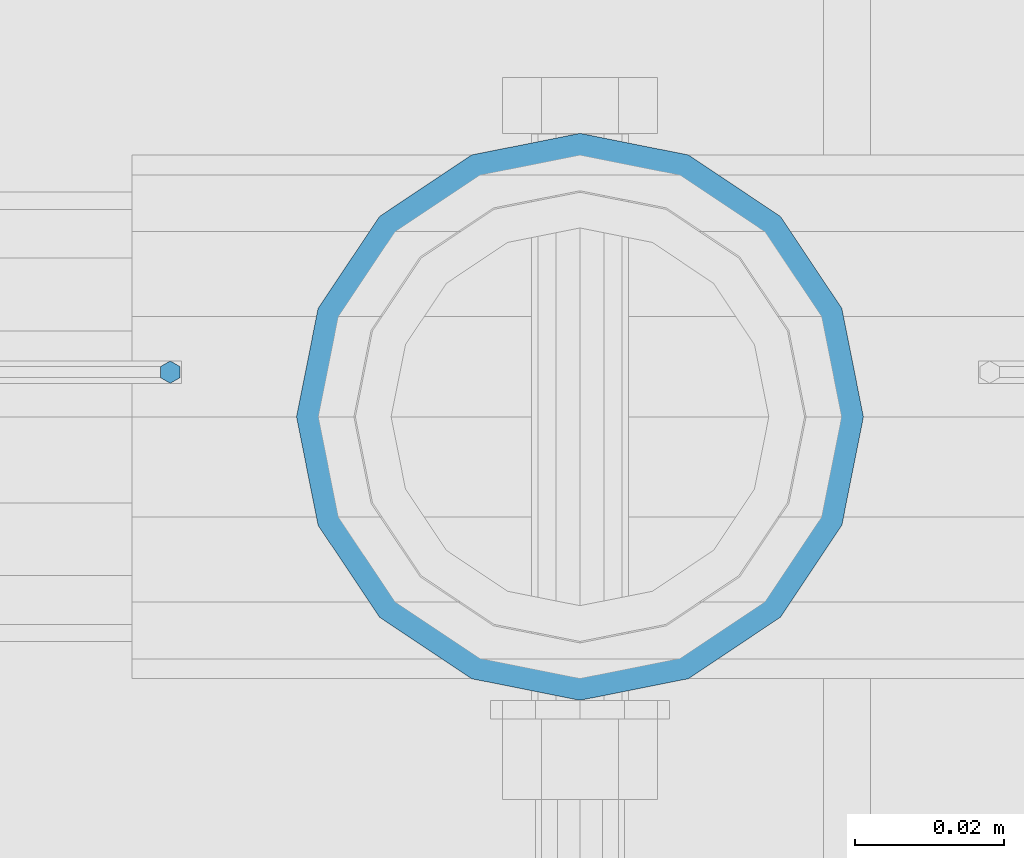
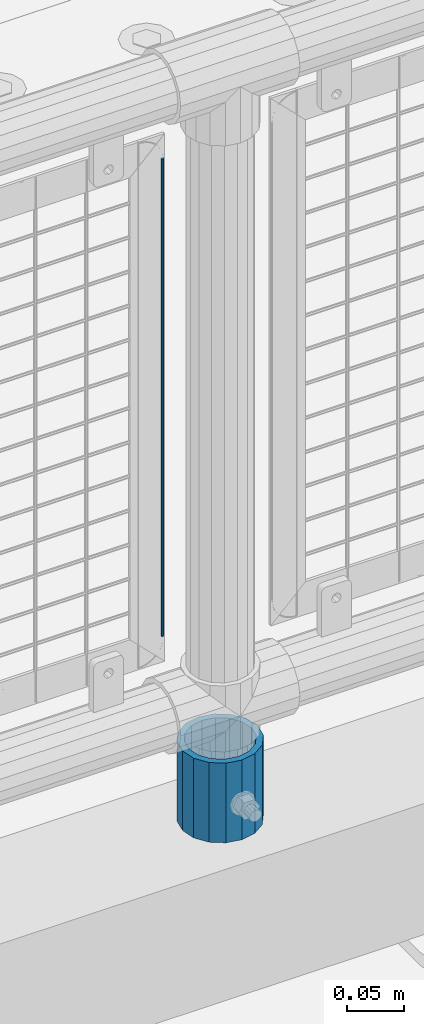
# One storey, part 87 of 240: 2 columns.
"""IFC2X3 building model written with IfcOpenShell, lengths in millimetres."""

from ifc_helpers import new_model, si_unit, frame, origin_with_axes, place, context, subcontext, project, spatial, faceted_brep, material, type_object, element, save


model = new_model("IFC2X3")

# Units and contexts
model_context = context("Model", 3, precision=1e-05, world=origin_with_axes())
body_context = subcontext(model_context, "Body", "Model", "MODEL_VIEW")
ifc_project = project(units=[si_unit("LENGTHUNIT", "METRE", prefix="MILLI"), si_unit("AREAUNIT", "SQUARE_METRE"), si_unit("VOLUMEUNIT", "CUBIC_METRE"), si_unit("MASSUNIT", "GRAM", prefix="KILO"), si_unit("TIMEUNIT", "SECOND"), si_unit("PLANEANGLEUNIT", "RADIAN"), si_unit("SOLIDANGLEUNIT", "STERADIAN"), si_unit("THERMODYNAMICTEMPERATUREUNIT", "DEGREE_CELSIUS"), si_unit("LUMINOUSINTENSITYUNIT", "LUMEN")], contexts=[model_context])

# Site, building, storey
site_placement = place(None, origin_with_axes())
site = spatial("IfcSite", under=ifc_project, at=site_placement, CompositionType="ELEMENT")
building_placement = place(site_placement, origin_with_axes())
building = spatial("IfcBuilding", under=site, at=building_placement, Name="Standard", CompositionType="ELEMENT")
storey_placement = place(building_placement, origin_with_axes())
storey = spatial("IfcBuildingStorey", under=building, at=storey_placement, Name="Undefined", CompositionType="ELEMENT", Elevation=0.0)

# Columns
ifc_material_1 = material(Name="Misc_Undefined")
column_type_1 = type_object("IfcColumnType", Name="D3", PredefinedType="NOTDEFINED")
column_1_placement = place(storey_placement, frame((51306.0, 34670.5, 378.020000000001), z_axis=(-1.0, 0.0, 0.0), x_axis=(0.0, 0.0, 1.0)))
element("IfcColumn", 1, at=column_1_placement, inside=storey, type_object=column_type_1, material=ifc_material_1, ObjectType="D3", context=body_context, shape_type="Brep", body=[
    faceted_brep([(-7.27595761418343e-12, -1.49999999999272, 0.0), (-7.27595761418343e-12, -0.749999999992724, -1.29903810567669), (510.0, -0.75, -1.29903810567339), (510.0, -1.5, 0.0), (0.0, 0.750000000007276, -1.29903810567669), (510.0, 0.75, -1.29903810567339), (0.0, 1.50000000000728, 0.0), (510.0, 1.5, 0.0), (0.0, 0.750000000007276, 1.29903810567669), (510.0, 0.75, 1.29903810567339), (-7.27595761418343e-12, -0.749999999992724, 1.29903810567669), (510.0, -0.75, 1.29903810567339)], [[[0, 1, 2, 3]], [[1, 4, 5, 2]], [[4, 6, 7, 5]], [[6, 8, 9, 7]], [[8, 10, 11, 9]], [[10, 0, 3, 11]], [[5, 7, 9, 11, 3, 2]], [[10, 8, 6, 4, 1, 0]]]),
])
ifc_material_2 = material()
column_type_2 = type_object("IfcColumnType", PredefinedType="NOTDEFINED")
column_2_placement = place(storey_placement, frame((51361.0, 34664.5, 168.02), z_axis=(0.0, 1.0, 0.0), x_axis=(0.0, 0.0, 1.0)))
element("IfcColumn", 2, at=column_2_placement, inside=storey, type_object=column_type_2, material=ifc_material_2, context=body_context, shape_type="Brep", body=[
    faceted_brep([(0.0, -31.75, 0.0), (0.0, -29.3331751572332, 12.1501989775934), (85.0, -29.3331751572332, 12.1501989775934), (85.0, -31.75, 0.0), (0.0, -22.4506403026753, 22.4506403026753), (85.0, -22.4506403026753, 22.4506403026753), (0.0, -12.1501989775934, 29.3331751572332), (85.0, -12.1501989775934, 29.3331751572332), (0.0, 0.0, 31.75), (85.0, 0.0, 31.75), (0.0, 12.1501989775934, 29.3331751572332), (85.0, 12.1501989775934, 29.3331751572332), (0.0, 22.4506403026753, 22.4506403026753), (85.0, 22.4506403026753, 22.4506403026753), (0.0, 29.3331751572332, 12.1501989775934), (85.0, 29.3331751572332, 12.1501989775934), (0.0, 31.75, 0.0), (85.0, 31.75, 0.0), (0.0, 29.3331751572332, -12.1501989775934), (85.0, 29.3331751572332, -12.1501989775934), (0.0, 22.4506403026753, -22.4506403026753), (85.0, 22.4506403026753, -22.4506403026753), (0.0, 12.1501989775934, -29.3331751572332), (85.0, 12.1501989775934, -29.3331751572332), (0.0, 0.0, -31.75), (85.0, 0.0, -31.75), (0.0, -12.1501989775934, -29.3331751572332), (85.0, -12.1501989775934, -29.3331751572332), (0.0, -22.4506403026753, -22.4506403026753), (85.0, -22.4506403026753, -22.4506403026753), (0.0, -29.3331751572332, -12.1501989775934), (85.0, -29.3331751572332, -12.1501989775934), (0.0, -38.0500000000029, 0.0), (0.0, -35.1536162120537, -14.5611046014892), (85.0, -35.1536162120537, -14.5611046014892), (85.0, -38.0500000000029, 0.0), (0.0, -26.9054130241493, -26.9054130241493), (85.0, -26.9054130241493, -26.9054130241493), (0.0, -14.5611046014892, -35.1536162120537), (85.0, -14.5611046014892, -35.1536162120537), (0.0, 0.0, -38.0500000000029), (85.0, 0.0, -38.0500000000029), (0.0, 14.5611046014892, -35.1536162120537), (85.0, 14.5611046014892, -35.1536162120537), (0.0, 26.9054130241493, -26.9054130241493), (85.0, 26.9054130241493, -26.9054130241493), (0.0, 35.1536162120537, -14.5611046014892), (85.0, 35.1536162120537, -14.5611046014892), (0.0, 38.0500000000029, 0.0), (85.0, 38.0500000000029, 0.0), (0.0, 35.1536162120537, 14.5611046014892), (85.0, 35.1536162120537, 14.5611046014892), (0.0, 26.9054130241493, 26.9054130241493), (85.0, 26.9054130241493, 26.9054130241493), (0.0, 14.5611046014892, 35.1536162120537), (85.0, 14.5611046014892, 35.1536162120537), (0.0, 0.0, 38.0500000000029), (85.0, 0.0, 38.0500000000029), (0.0, -14.5611046014892, 35.1536162120537), (85.0, -14.5611046014892, 35.1536162120537), (0.0, -26.9054130241493, 26.9054130241493), (85.0, -26.9054130241493, 26.9054130241493), (0.0, -35.1536162120537, 14.5611046014892), (85.0, -35.1536162120537, 14.5611046014892)], [[[0, 1, 2, 3]], [[1, 4, 5, 2]], [[4, 6, 7, 5]], [[6, 8, 9, 7]], [[8, 10, 11, 9]], [[10, 12, 13, 11]], [[12, 14, 15, 13]], [[14, 16, 17, 15]], [[16, 18, 19, 17]], [[18, 20, 21, 19]], [[20, 22, 23, 21]], [[22, 24, 25, 23]], [[24, 26, 27, 25]], [[26, 28, 29, 27]], [[28, 30, 31, 29]], [[30, 0, 3, 31]], [[32, 33, 34, 35]], [[33, 36, 37, 34]], [[36, 38, 39, 37]], [[38, 40, 41, 39]], [[40, 42, 43, 41]], [[42, 44, 45, 43]], [[44, 46, 47, 45]], [[46, 48, 49, 47]], [[48, 50, 51, 49]], [[50, 52, 53, 51]], [[52, 54, 55, 53]], [[54, 56, 57, 55]], [[56, 58, 59, 57]], [[58, 60, 61, 59]], [[60, 62, 63, 61]], [[62, 32, 35, 63]], [[37, 39, 41, 43, 45, 47, 49, 51, 53, 55, 57, 59, 61, 63, 35, 34], [5, 7, 9, 11, 13, 15, 17, 19, 21, 23, 25, 27, 29, 31, 3, 2]], [[62, 60, 58, 56, 54, 52, 50, 48, 46, 44, 42, 40, 38, 36, 33, 32], [30, 28, 26, 24, 22, 20, 18, 16, 14, 12, 10, 8, 6, 4, 1, 0]]]),
])

save(model, "model.ifc")
